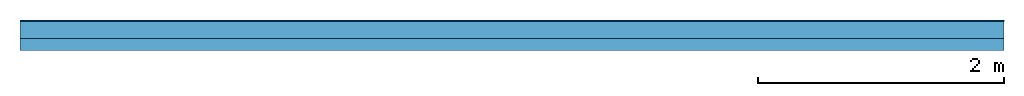
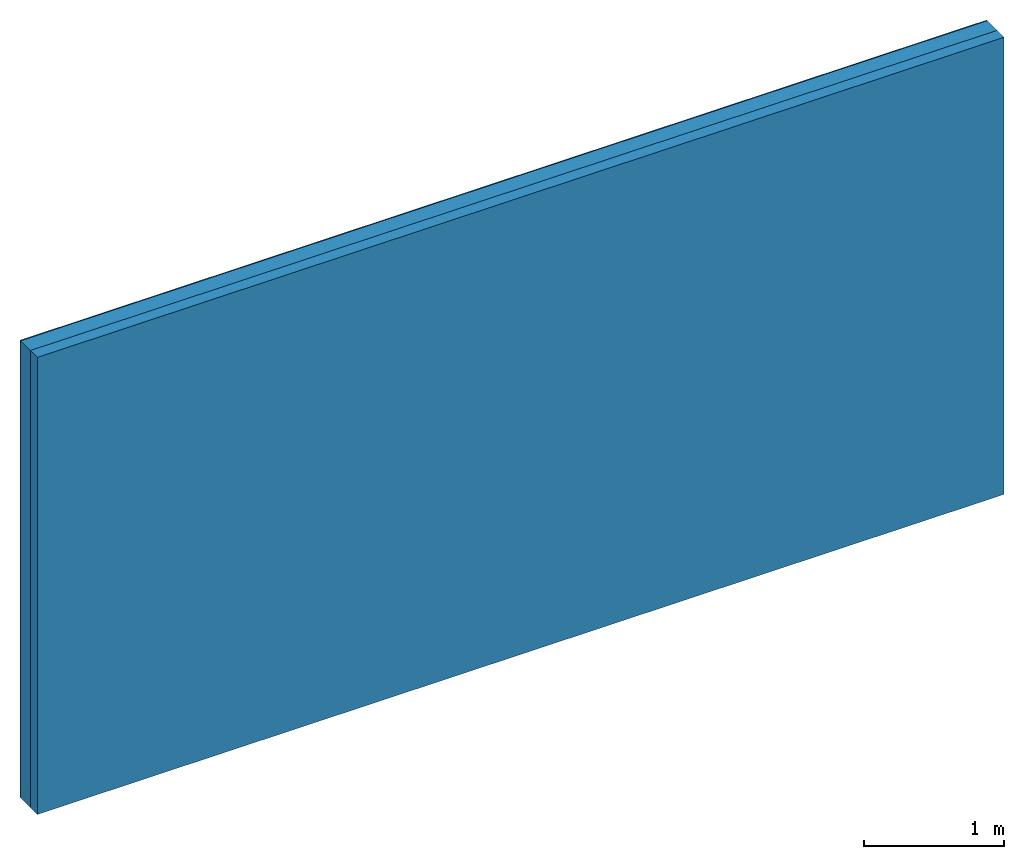
# One storey: 2 plates, 1 member, 1 element without a shape of its own.
"""IFC4 building model written with IfcOpenShell, lengths in metres."""

from ifc_helpers import new_model, si_unit, derived_unit, direction, frame, frame_2d, origin, origin_with_axes, place, context, project, spatial, rectangle, extrude, material, layer, layer_set, type_object, element, aggregate, save


model = new_model("IFC4")

# Units and contexts
plan_context = context("Plan", 3, precision=1e-05, world=origin(), true_north=direction((0.0, 1.0)))
model_context = context("Model", 3, precision=1e-05, world=origin(), true_north=direction((0.0, 1.0)))
ifc_project = project(units=[si_unit("LENGTHUNIT", "METRE"), derived_unit("SOUNDPRESSUREUNIT", [(si_unit("PRESSUREUNIT", "PASCAL", prefix="MICRO"), 0)]), si_unit("ENERGYUNIT", "JOULE", prefix="MEGA"), si_unit("MASSUNIT", "GRAM", prefix="KILO"), derived_unit("THERMALTRANSMITTANCEUNIT", [(si_unit("POWERUNIT", "WATT"), 1), (si_unit("AREAUNIT", "SQUARE_METRE"), -1), (si_unit("THERMODYNAMICTEMPERATUREUNIT", "KELVIN"), -1)]), derived_unit("AREADENSITYUNIT", [(si_unit("MASSUNIT", "GRAM", prefix="KILO"), 1), (si_unit("AREAUNIT", "SQUARE_METRE"), -1)]), derived_unit("USERDEFINED", [(si_unit("ENERGYUNIT", "JOULE", prefix="MEGA"), 1), (si_unit("AREAUNIT", "SQUARE_METRE"), -1)])], contexts=[plan_context, model_context])

# Site, building, storey
site = spatial("IfcSite", under=ifc_project)
building_placement = place(None, origin())
building = spatial("IfcBuilding", under=site, at=building_placement)
storey_placement = place(building_placement, origin())
storey = spatial("IfcBuildingStorey", under=building, at=storey_placement)

# Wall, member, plates
ifc_material_1 = material(Name="Mineral Knauf SM 700")
ifc_layer_1 = layer(ifc_material_1, 0.01, Name="Surface 1")
ifc_material_2 = material(Category="10.008")
ifc_layer_2 = layer(ifc_material_2, 0.14, Name="outside 1st layer")
ifc_material_3 = material(Name="of the art")
ifc_layer_3 = layer(ifc_material_3, 0.0, Name="Bond")
ifc_layer_4 = layer(None, 0.1, Name="Support")
ifc_layer_set = layer_set([ifc_layer_1, ifc_layer_2, ifc_layer_3, ifc_layer_4])
wall_type = type_object("IfcWallType", Name="D1199", PredefinedType="NOTDEFINED", material=ifc_layer_set)
wall_placement = place(None, frame((0.0, 0.0, 0.0), z_axis=(0.0, -1.0, 0.0), x_axis=(1.0, 0.0, 0.0)))
wall = element("IfcWall", 1, at=wall_placement, inside=storey, type_object=wall_type, material=ifc_layer_set, Name="Wall #1")
ifc_material_4 = material(Name="OSB")
member_placement = place(wall_placement, origin())
member = element("IfcMember", 2, at=member_placement, material=ifc_material_4, Name="Support", context=plan_context, shape_type="SweptSolid", body=[
    extrude(rectangle(XDim=1.0, YDim=0.1, at=frame_2d((0.5, 0.05), x_axis=(1.0, 0.0))), frame((0.0, 4.0, 0.15), z_axis=(0.0, -1.0, 0.0), x_axis=(1.0, 0.0, 0.0)), (0.0, 0.0, 1.0), 4.0),
    extrude(rectangle(XDim=1.0, YDim=0.1, at=frame_2d((0.5, 0.05), x_axis=(1.0, 0.0))), frame((1.0, 4.0, 0.15), z_axis=(0.0, -1.0, 0.0), x_axis=(1.0, 0.0, 0.0)), (0.0, 0.0, 1.0), 4.0),
    extrude(rectangle(XDim=1.0, YDim=0.1, at=frame_2d((0.5, 0.05), x_axis=(1.0, 0.0))), frame((2.0, 4.0, 0.15), z_axis=(0.0, -1.0, 0.0), x_axis=(1.0, 0.0, 0.0)), (0.0, 0.0, 1.0), 4.0),
    extrude(rectangle(XDim=1.0, YDim=0.1, at=frame_2d((0.5, 0.05), x_axis=(1.0, 0.0))), frame((3.0, 4.0, 0.15), z_axis=(0.0, -1.0, 0.0), x_axis=(1.0, 0.0, 0.0)), (0.0, 0.0, 1.0), 4.0),
    extrude(rectangle(XDim=1.0, YDim=0.1, at=frame_2d((0.5, 0.05), x_axis=(1.0, 0.0))), frame((4.0, 4.0, 0.15), z_axis=(0.0, -1.0, 0.0), x_axis=(1.0, 0.0, 0.0)), (0.0, 0.0, 1.0), 4.0),
    extrude(rectangle(XDim=1.0, YDim=0.1, at=frame_2d((0.5, 0.05), x_axis=(1.0, 0.0))), frame((5.0, 4.0, 0.15), z_axis=(0.0, -1.0, 0.0), x_axis=(1.0, 0.0, 0.0)), (0.0, 0.0, 1.0), 4.0),
    extrude(rectangle(XDim=1.0, YDim=0.1, at=frame_2d((0.5, 0.05), x_axis=(1.0, 0.0))), frame((6.0, 4.0, 0.15), z_axis=(0.0, -1.0, 0.0), x_axis=(1.0, 0.0, 0.0)), (0.0, 0.0, 1.0), 4.0),
    extrude(rectangle(XDim=1.0, YDim=0.1, at=frame_2d((0.5, 0.05), x_axis=(1.0, 0.0))), frame((7.0, 4.0, 0.15), z_axis=(0.0, -1.0, 0.0), x_axis=(1.0, 0.0, 0.0)), (0.0, 0.0, 1.0), 4.0),
])
plate_1_placement = place(wall_placement, origin())
plate_1 = element("IfcPlate", 3, at=plate_1_placement, material=ifc_material_1, Name="Surface 1", context=plan_context, shape_type="SweptSolid", body=[
    extrude(rectangle(XDim=8.0, YDim=4.0, at=frame_2d((4.0, 2.0), x_axis=(1.0, 0.0))), origin_with_axes(), (0.0, 0.0, 1.0), 0.01),
])
plate_2_placement = place(wall_placement, origin())
plate_2 = element("IfcPlate", 4, at=plate_2_placement, material=ifc_material_2, Name="outside 1st layer", context=plan_context, shape_type="SweptSolid", body=[
    extrude(rectangle(XDim=8.0, YDim=4.0, at=frame_2d((4.0, 2.0), x_axis=(1.0, 0.0))), frame((0.0, 0.0, 0.01), z_axis=(0.0, 0.0, 1.0), x_axis=(1.0, 0.0, 0.0)), (0.0, 0.0, 1.0), 0.14),
])
aggregate(wall, [plate_1, plate_2, member])

save(model, "model.ifc")
